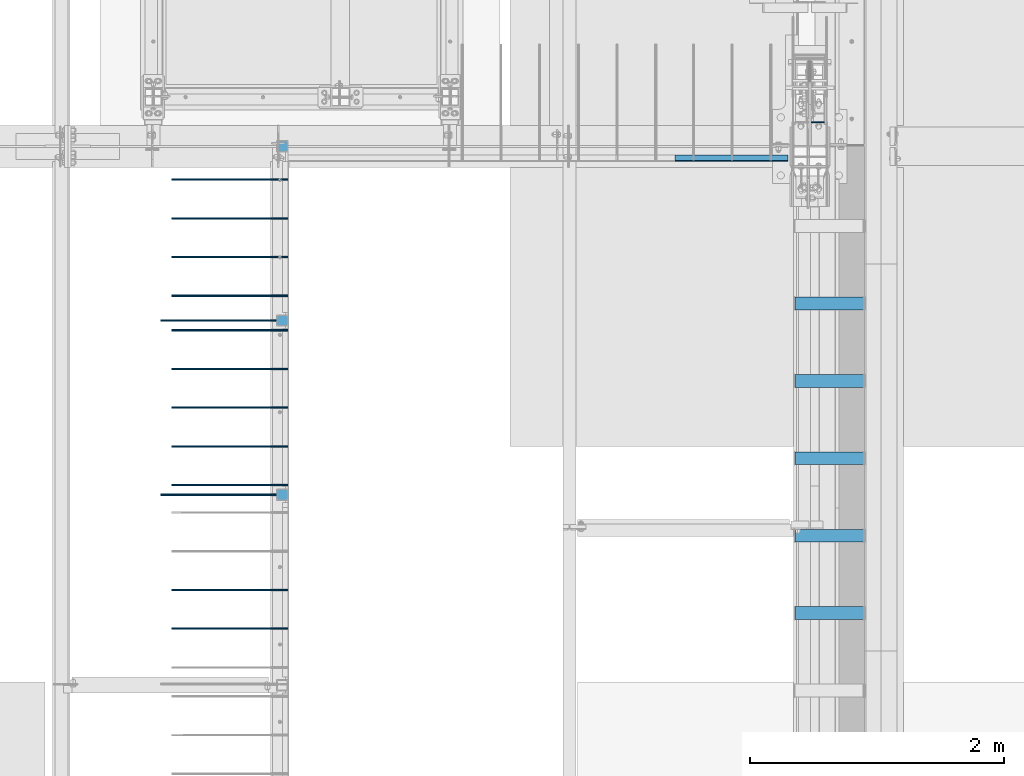
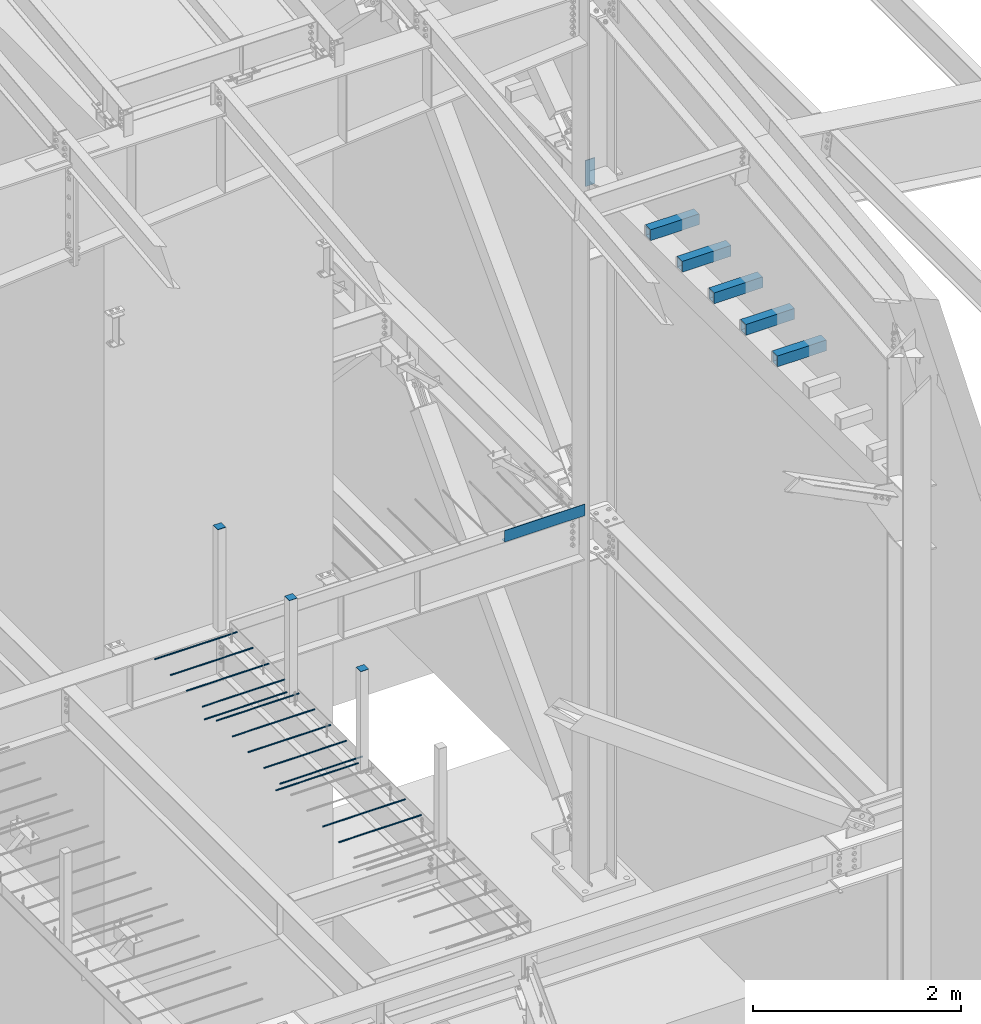
# One storey, part 822 of 1179: 23 beams, 23 elements without a shape of their own.
"""IFC2X3 building model written with IfcOpenShell, lengths in millimetres."""

from ifc_helpers import new_model, si_unit, frame, origin_with_axes, place, context, subcontext, project, spatial, faceted_brep, material, type_object, element, aggregate, save


model = new_model("IFC2X3")

# Units and contexts
model_context = context("Model", 3, precision=1e-05, world=origin_with_axes())
body_context = subcontext(model_context, "Body", "Model", "MODEL_VIEW")
ifc_project = project(units=[si_unit("LENGTHUNIT", "METRE", prefix="MILLI"), si_unit("AREAUNIT", "SQUARE_METRE"), si_unit("VOLUMEUNIT", "CUBIC_METRE"), si_unit("MASSUNIT", "GRAM", prefix="KILO"), si_unit("TIMEUNIT", "SECOND"), si_unit("PLANEANGLEUNIT", "RADIAN"), si_unit("SOLIDANGLEUNIT", "STERADIAN"), si_unit("THERMODYNAMICTEMPERATUREUNIT", "DEGREE_CELSIUS"), si_unit("LUMINOUSINTENSITYUNIT", "LUMEN")], contexts=[model_context])

# Site, building, storey
site_placement = place(None, origin_with_axes())
site = spatial("IfcSite", under=ifc_project, at=site_placement, CompositionType="ELEMENT")
building_placement = place(site_placement, origin_with_axes())
building = spatial("IfcBuilding", under=site, at=building_placement, Name="Undefined", CompositionType="ELEMENT")
storey_placement = place(building_placement, origin_with_axes())
storey = spatial("IfcBuildingStorey", under=building, at=storey_placement, Name="Undefined", CompositionType="ELEMENT", Elevation=0.0)

# Assembly, beam
assembly_1_placement = place(storey_placement, origin_with_axes())
assembly_1 = element("IfcElementAssembly", 1, at=assembly_1_placement, inside=storey, Name="BEAM", AssemblyPlace="NOTDEFINED", PredefinedType="RIGID_FRAME")
ifc_material_1 = material(Name="STEEL/A36")
beam_type_1 = type_object("IfcBeamType", PredefinedType="NOTDEFINED")
beam_1_placement = place(assembly_1_placement, frame((23692.6435, 11366.5, 4235.45000610352), z_axis=(1.0, 0.0, 0.0), x_axis=(0.0, 0.0, -1.0)))
beam_1 = element("IfcBeam", 2, at=beam_1_placement, type_object=beam_type_1, material=ifc_material_1, Name="BENT_PLATE", context=body_context, shape_type="Brep", body=[
    faceted_brep([(0.0, -3.17499999999927, -445.2935), (0.0, -3.17499999999927, 445.2935), (0.0, 3.17499999999927, 445.2935), (0.0, 3.17499999999927, -445.2935), (127.000006103516, 3.17499999999927, 445.2935), (127.000006103516, 3.17499999999927, -445.2935), (133.350006103517, -3.17499999999927, -445.2935), (133.350006103517, -3.17499999999927, 445.2935), (127.000006103516, 47.6249992370613, 445.2935), (127.000006103516, 47.6249992370613, -445.2935), (133.350006103517, 47.6249992370613, 445.2935), (133.350006103517, 47.6249992370613, -445.2935)], [[[0, 1, 2, 3]], [[3, 2, 4, 5]], [[1, 0, 6, 7]], [[5, 4, 8, 9]], [[4, 2, 1, 7, 10, 8]], [[7, 6, 11, 10]], [[6, 0, 3, 5, 9, 11]], [[10, 11, 9, 8]]]),
])
aggregate(assembly_1, [beam_1])

assembly_2_placement = place(storey_placement, origin_with_axes())
assembly_2 = element("IfcElementAssembly", 3, at=assembly_2_placement, inside=storey, Name="COLUMN", AssemblyPlace="NOTDEFINED", PredefinedType="RIGID_FRAME")
beam_type_2 = type_object("IfcBeamType", PredefinedType="NOTDEFINED")
beam_2_placement = place(assembly_2_placement, frame((20154.9, 8693.15, 5299.8685), z_axis=(1.0, 0.0, 0.0), x_axis=(0.0, 1.0, 0.0)))
beam_2 = element("IfcBeam", 4, at=beam_2_placement, type_object=beam_type_2, material=ifc_material_1, Name="PLATE", context=body_context, shape_type="Brep", body=[
    faceted_brep([(0.0, 2.38150000000041, -44.4500000000007), (0.0, 2.38150000000041, 44.4500000000007), (88.9000000000015, 2.38150000000041, 44.4500000000007), (88.9000000000015, 2.38150000000041, -44.4500000000007), (0.0, -2.38150000000041, 44.4500000000007), (88.9000000000015, -2.38150000000041, 44.4500000000007), (0.0, -2.38150000000041, -44.4500000000007), (88.9000000000015, -2.38150000000041, -44.4500000000007)], [[[0, 1, 2, 3]], [[1, 4, 5, 2]], [[4, 6, 7, 5]], [[6, 0, 3, 7]], [[5, 7, 3, 2]], [[6, 4, 1, 0]]]),
])
aggregate(assembly_2, [beam_2])

assembly_3_placement = place(storey_placement, origin_with_axes())
assembly_3 = element("IfcElementAssembly", 5, at=assembly_3_placement, inside=storey, Name="COLUMN", AssemblyPlace="NOTDEFINED", PredefinedType="RIGID_FRAME")
beam_3_placement = place(assembly_3_placement, frame((20154.9, 10064.75, 5299.8685), z_axis=(1.0, 0.0, 0.0), x_axis=(0.0, 1.0, 0.0)))
beam_3 = element("IfcBeam", 6, at=beam_3_placement, type_object=beam_type_2, material=ifc_material_1, Name="PLATE", context=body_context, shape_type="Brep", body=[
    faceted_brep([(0.0, 2.38150000000041, -44.4500000000007), (0.0, 2.38150000000041, 44.4500000000007), (88.9000000000015, 2.38150000000041, 44.4500000000007), (88.9000000000015, 2.38150000000041, -44.4500000000007), (0.0, -2.38150000000041, 44.4500000000007), (88.9000000000015, -2.38150000000041, 44.4500000000007), (0.0, -2.38150000000041, -44.4500000000007), (88.9000000000015, -2.38150000000041, -44.4500000000007)], [[[0, 1, 2, 3]], [[1, 4, 5, 2]], [[4, 6, 7, 5]], [[6, 0, 3, 7]], [[5, 7, 3, 2]], [[6, 4, 1, 0]]]),
])
aggregate(assembly_3, [beam_3])

assembly_4_placement = place(storey_placement, origin_with_axes())
assembly_4 = element("IfcElementAssembly", 7, at=assembly_4_placement, inside=storey, Name="COLUMN", AssemblyPlace="NOTDEFINED", PredefinedType="RIGID_FRAME")
beam_4_placement = place(assembly_4_placement, frame((20154.9, 11436.35, 5299.8685), z_axis=(1.0, 0.0, 0.0), x_axis=(0.0, 1.0, 0.0)))
beam_4 = element("IfcBeam", 8, at=beam_4_placement, type_object=beam_type_2, material=ifc_material_1, Name="PLATE", context=body_context, shape_type="Brep", body=[
    faceted_brep([(0.0, 2.38150000000041, -44.4500000000007), (0.0, 2.38150000000041, 44.4500000000007), (88.9000000000015, 2.38150000000041, 44.4500000000007), (88.9000000000015, 2.38150000000041, -44.4500000000007), (0.0, -2.38150000000041, 44.4500000000007), (88.9000000000015, -2.38150000000041, 44.4500000000007), (0.0, -2.38150000000041, -44.4500000000007), (88.9000000000015, -2.38150000000041, -44.4500000000007)], [[[0, 1, 2, 3]], [[1, 4, 5, 2]], [[4, 6, 7, 5]], [[6, 0, 3, 7]], [[5, 7, 3, 2]], [[6, 4, 1, 0]]]),
])
aggregate(assembly_4, [beam_4])

assembly_5_placement = place(storey_placement, origin_with_axes())
assembly_5 = element("IfcElementAssembly", 9, at=assembly_5_placement, inside=storey, Name="COLUMN", AssemblyPlace="NOTDEFINED", PredefinedType="RIGID_FRAME")
ifc_material_2 = material(Name="STEEL/A572-GR.50")
beam_type_3 = type_object("IfcBeamType", PredefinedType="NOTDEFINED")
beam_5_placement = place(assembly_5_placement, frame((24317.325, 11671.3, 7861.3), z_axis=(0.0, 0.0, 1.0), x_axis=(1.0, 0.0, 0.0)))
beam_5 = element("IfcBeam", 10, at=beam_5_placement, type_object=beam_type_3, material=ifc_material_2, Name="PLATE", context=body_context, shape_type="Brep", body=[
    faceted_brep([(0.0, 4.76250000000073, -152.4), (0.0, 4.76250000000073, 152.4), (104.775000000001, 4.76250000000073, 152.4), (104.775000000001, 4.76250000000073, -152.4), (0.0, -4.76250000000073, 152.4), (104.775000000001, -4.76250000000073, 152.4), (0.0, -4.76250000000073, -152.4), (104.775000000001, -4.76250000000073, -152.4)], [[[0, 1, 2, 3]], [[1, 4, 5, 2]], [[4, 6, 7, 5]], [[6, 0, 3, 7]], [[5, 7, 3, 2]], [[6, 4, 1, 0]]]),
])
aggregate(assembly_5, [beam_5])

assembly_6_placement = place(storey_placement, origin_with_axes())
assembly_6 = element("IfcElementAssembly", 11, at=assembly_6_placement, inside=storey, Name="BEAM", AssemblyPlace="NOTDEFINED", PredefinedType="RIGID_FRAME")
ifc_material_3 = material()
beam_type_4 = type_object("IfcBeamType", Name="HSS5X4X3/8", PredefinedType="NOTDEFINED")
beam_6_placement = place(assembly_6_placement, frame((24180.8, 7805.75703850264, 8077.19999998781), z_axis=(0.0, 0.0, 1.0), x_axis=(1.0, 0.0, 0.0)))
beam_6 = element("IfcBeam", 12, at=beam_6_placement, type_object=beam_type_4, material=ifc_material_3, Name="BEAM", ObjectType="HSS5X4X3/8", context=body_context, shape_type="Brep", body=[
    faceted_brep([(9.52500000000146, 41.2750000000015, -53.9750000000004), (9.52500000000146, -41.2750000000015, -53.9750000000004), (549.274999999994, -41.2750000000015, -53.9750000000004), (549.274999999994, 41.2750000000015, -53.9750000000004), (9.52500000000146, -41.2750000000015, 53.9750000000004), (549.274999999994, -41.2750000000015, 53.9750000000004), (9.52500000000146, 41.2750000000015, 53.9750000000004), (549.274999999994, 41.2750000000015, 53.9750000000004), (9.52500000000146, 50.7999999999993, -63.5), (9.52500000000146, 50.7999999999993, 63.5), (549.274999999994, 50.7999999999993, 63.5), (549.274999999994, 50.7999999999993, -63.5), (9.52500000000146, -50.7999999999993, 63.5), (549.274999999994, -50.7999999999993, 63.5), (9.52500000000146, -50.7999999999993, -63.5), (549.274999999994, -50.7999999999993, -63.5)], [[[0, 1, 2, 3]], [[1, 4, 5, 2]], [[4, 6, 7, 5]], [[6, 0, 3, 7]], [[8, 9, 10, 11]], [[9, 12, 13, 10]], [[12, 14, 15, 13]], [[14, 8, 11, 15]], [[13, 15, 11, 10], [5, 7, 3, 2]], [[14, 12, 9, 8], [6, 4, 1, 0]]]),
])
aggregate(assembly_6, [beam_6])

assembly_7_placement = place(storey_placement, origin_with_axes())
assembly_7 = element("IfcElementAssembly", 13, at=assembly_7_placement, inside=storey, Name="BEAM", AssemblyPlace="NOTDEFINED", PredefinedType="RIGID_FRAME")
beam_7_placement = place(assembly_7_placement, frame((24180.8, 8415.35703850264, 8077.19999998781), z_axis=(0.0, 0.0, 1.0), x_axis=(1.0, 0.0, 0.0)))
beam_7 = element("IfcBeam", 14, at=beam_7_placement, type_object=beam_type_4, material=ifc_material_3, Name="BEAM", ObjectType="HSS5X4X3/8", context=body_context, shape_type="Brep", body=[
    faceted_brep([(9.52500000000146, 41.2750000000015, -53.9750000000004), (9.52500000000146, -41.2750000000015, -53.9750000000004), (549.274999999994, -41.2750000000015, -53.9750000000004), (549.274999999994, 41.2750000000015, -53.9750000000004), (9.52500000000146, -41.2750000000015, 53.9750000000004), (549.274999999994, -41.2750000000015, 53.9750000000004), (9.52500000000146, 41.2750000000015, 53.9750000000004), (549.274999999994, 41.2750000000015, 53.9750000000004), (9.52500000000146, 50.7999999999993, -63.5), (9.52500000000146, 50.7999999999993, 63.5), (549.274999999994, 50.7999999999993, 63.5), (549.274999999994, 50.7999999999993, -63.5), (9.52500000000146, -50.7999999999993, 63.5), (549.274999999994, -50.7999999999993, 63.5), (9.52500000000146, -50.7999999999993, -63.5), (549.274999999994, -50.7999999999993, -63.5)], [[[0, 1, 2, 3]], [[1, 4, 5, 2]], [[4, 6, 7, 5]], [[6, 0, 3, 7]], [[8, 9, 10, 11]], [[9, 12, 13, 10]], [[12, 14, 15, 13]], [[14, 8, 11, 15]], [[13, 15, 11, 10], [5, 7, 3, 2]], [[14, 12, 9, 8], [6, 4, 1, 0]]]),
])
aggregate(assembly_7, [beam_7])

assembly_8_placement = place(storey_placement, origin_with_axes())
assembly_8 = element("IfcElementAssembly", 15, at=assembly_8_placement, inside=storey, Name="BEAM", AssemblyPlace="NOTDEFINED", PredefinedType="RIGID_FRAME")
beam_8_placement = place(assembly_8_placement, frame((24180.8, 9024.95703850264, 8077.19999998781), z_axis=(0.0, 0.0, 1.0), x_axis=(1.0, 0.0, 0.0)))
beam_8 = element("IfcBeam", 16, at=beam_8_placement, type_object=beam_type_4, material=ifc_material_3, Name="BEAM", ObjectType="HSS5X4X3/8", context=body_context, shape_type="Brep", body=[
    faceted_brep([(9.52500000000146, 41.2750000000015, -53.9750000000004), (9.52500000000146, -41.2750000000015, -53.9750000000004), (549.274999999994, -41.2750000000015, -53.9750000000004), (549.274999999994, 41.2750000000015, -53.9750000000004), (9.52500000000146, -41.2750000000015, 53.9750000000004), (549.274999999994, -41.2750000000015, 53.9750000000004), (9.52500000000146, 41.2750000000015, 53.9750000000004), (549.274999999994, 41.2750000000015, 53.9750000000004), (9.52500000000146, 50.7999999999993, -63.5), (9.52500000000146, 50.7999999999993, 63.5), (549.274999999994, 50.7999999999993, 63.5), (549.274999999994, 50.7999999999993, -63.5), (9.52500000000146, -50.7999999999993, 63.5), (549.274999999994, -50.7999999999993, 63.5), (9.52500000000146, -50.7999999999993, -63.5), (549.274999999994, -50.7999999999993, -63.5)], [[[0, 1, 2, 3]], [[1, 4, 5, 2]], [[4, 6, 7, 5]], [[6, 0, 3, 7]], [[8, 9, 10, 11]], [[9, 12, 13, 10]], [[12, 14, 15, 13]], [[14, 8, 11, 15]], [[13, 15, 11, 10], [5, 7, 3, 2]], [[14, 12, 9, 8], [6, 4, 1, 0]]]),
])
aggregate(assembly_8, [beam_8])

assembly_9_placement = place(storey_placement, origin_with_axes())
assembly_9 = element("IfcElementAssembly", 17, at=assembly_9_placement, inside=storey, Name="BEAM", AssemblyPlace="NOTDEFINED", PredefinedType="RIGID_FRAME")
beam_9_placement = place(assembly_9_placement, frame((24180.8, 9634.55703850264, 8077.19999998781), z_axis=(0.0, 0.0, 1.0), x_axis=(1.0, 0.0, 0.0)))
beam_9 = element("IfcBeam", 18, at=beam_9_placement, type_object=beam_type_4, material=ifc_material_3, Name="BEAM", ObjectType="HSS5X4X3/8", context=body_context, shape_type="Brep", body=[
    faceted_brep([(9.52500000000146, 41.2750000000015, -53.9750000000004), (9.52500000000146, -41.2750000000015, -53.9750000000004), (549.274999999994, -41.2750000000015, -53.9750000000004), (549.274999999994, 41.2750000000015, -53.9750000000004), (9.52500000000146, -41.2750000000015, 53.9750000000004), (549.274999999994, -41.2750000000015, 53.9750000000004), (9.52500000000146, 41.2750000000015, 53.9750000000004), (549.274999999994, 41.2750000000015, 53.9750000000004), (9.52500000000146, 50.7999999999993, -63.5), (9.52500000000146, 50.7999999999993, 63.5), (549.274999999994, 50.7999999999993, 63.5), (549.274999999994, 50.7999999999993, -63.5), (9.52500000000146, -50.7999999999993, 63.5), (549.274999999994, -50.7999999999993, 63.5), (9.52500000000146, -50.7999999999993, -63.5), (549.274999999994, -50.7999999999993, -63.5)], [[[0, 1, 2, 3]], [[1, 4, 5, 2]], [[4, 6, 7, 5]], [[6, 0, 3, 7]], [[8, 9, 10, 11]], [[9, 12, 13, 10]], [[12, 14, 15, 13]], [[14, 8, 11, 15]], [[13, 15, 11, 10], [5, 7, 3, 2]], [[14, 12, 9, 8], [6, 4, 1, 0]]]),
])
aggregate(assembly_9, [beam_9])

assembly_10_placement = place(storey_placement, origin_with_axes())
assembly_10 = element("IfcElementAssembly", 19, at=assembly_10_placement, inside=storey, Name="BEAM", AssemblyPlace="NOTDEFINED", PredefinedType="RIGID_FRAME")
beam_10_placement = place(assembly_10_placement, frame((24180.8, 10244.1570385026, 8077.19999998781), z_axis=(0.0, 0.0, 1.0), x_axis=(1.0, 0.0, 0.0)))
beam_10 = element("IfcBeam", 20, at=beam_10_placement, type_object=beam_type_4, material=ifc_material_3, Name="BEAM", ObjectType="HSS5X4X3/8", context=body_context, shape_type="Brep", body=[
    faceted_brep([(9.52500000000146, 41.2750000000015, -53.9750000000004), (9.52500000000146, -41.2750000000015, -53.9750000000004), (549.274999999994, -41.2750000000015, -53.9750000000004), (549.274999999994, 41.2750000000015, -53.9750000000004), (9.52500000000146, -41.2750000000015, 53.9750000000004), (549.274999999994, -41.2750000000015, 53.9750000000004), (9.52500000000146, 41.2750000000015, 53.9750000000004), (549.274999999994, 41.2750000000015, 53.9750000000004), (9.52500000000146, 50.7999999999993, -63.5), (9.52500000000146, 50.7999999999993, 63.5), (549.274999999994, 50.7999999999993, 63.5), (549.274999999994, 50.7999999999993, -63.5), (9.52500000000146, -50.7999999999993, 63.5), (549.274999999994, -50.7999999999993, 63.5), (9.52500000000146, -50.7999999999993, -63.5), (549.274999999994, -50.7999999999993, -63.5)], [[[0, 1, 2, 3]], [[1, 4, 5, 2]], [[4, 6, 7, 5]], [[6, 0, 3, 7]], [[8, 9, 10, 11]], [[9, 12, 13, 10]], [[12, 14, 15, 13]], [[14, 8, 11, 15]], [[13, 15, 11, 10], [5, 7, 3, 2]], [[14, 12, 9, 8], [6, 4, 1, 0]]]),
])
aggregate(assembly_10, [beam_10])

assembly_11_placement = place(storey_placement, origin_with_axes())
assembly_11 = element("IfcElementAssembly", 21, at=assembly_11_placement, inside=storey, Name="#4 DOWEL", AssemblyPlace="NOTDEFINED", PredefinedType="NOTDEFINED")
ifc_material_4 = material(Name="REBAR/A615-40")
beam_type_5 = type_object("IfcBeamType", Name="#4 DOWEL", PredefinedType="NOTDEFINED")
beam_11_placement = place(assembly_11_placement, frame((19284.95, 10033.0, 4203.70000610352), z_axis=(0.0, 0.0, 1.0), x_axis=(1.0, 0.0, 0.0)))
beam_11 = element("IfcBeam", 22, at=beam_11_placement, type_object=beam_type_5, material=ifc_material_4, Name="#4 DOWEL", ObjectType="#4 DOWEL", context=body_context, shape_type="Brep", body=[
    faceted_brep([(0.0, -6.34999999999854, 0.0), (0.0, -4.49012806053361, -4.49012806053452), (914.399999999994, -4.49012806053452, -4.49012806042992), (914.399999999994, -6.34999999999991, 1.0550138540566e-10), (0.0, 0.0, -6.34999999999991), (914.399999999994, 0.0, -6.34999999989668), (0.0, 4.49012806053361, -4.49012806053452), (914.399999999994, 4.49012806053452, -4.49012806042992), (0.0, 6.34999999999854, 0.0), (914.399999999994, 6.34999999999991, 1.0550138540566e-10), (0.0, 4.49012806053361, 4.49012806053452), (914.399999999995, 4.49012806053452, 4.49012806064184), (0.0, 0.0, 6.34999999999991), (914.399999999995, 0.0, 6.35000000010768), (0.0, -4.49012806053361, 4.49012806053452), (914.399999999995, -4.49012806053452, 4.49012806064184)], [[[0, 1, 2, 3]], [[1, 4, 5, 2]], [[4, 6, 7, 5]], [[6, 8, 9, 7]], [[8, 10, 11, 9]], [[10, 12, 13, 11]], [[12, 14, 15, 13]], [[14, 0, 3, 15]], [[5, 7, 9, 11, 13, 15, 3, 2]], [[14, 12, 10, 8, 6, 4, 1, 0]]]),
])
aggregate(assembly_11, [beam_11])

assembly_12_placement = place(storey_placement, origin_with_axes())
assembly_12 = element("IfcElementAssembly", 23, at=assembly_12_placement, inside=storey, Name="#4 DOWEL", AssemblyPlace="NOTDEFINED", PredefinedType="NOTDEFINED")
beam_12_placement = place(assembly_12_placement, frame((19196.05, 8737.6, 4203.70000610352), z_axis=(0.0, 0.0, 1.0), x_axis=(1.0, 0.0, 0.0)))
beam_12 = element("IfcBeam", 24, at=beam_12_placement, type_object=beam_type_5, material=ifc_material_4, Name="#4 DOWEL", ObjectType="#4 DOWEL", context=body_context, shape_type="Brep", body=[
    faceted_brep([(0.0, -6.34999999999854, 0.0), (0.0, -4.49012806053361, -4.49012806053452), (914.399999999994, -4.49012806053452, -4.49012806042992), (914.399999999994, -6.34999999999991, 1.0550138540566e-10), (0.0, 0.0, -6.34999999999991), (914.399999999994, 0.0, -6.34999999989668), (0.0, 4.49012806053361, -4.49012806053452), (914.399999999994, 4.49012806053452, -4.49012806042992), (0.0, 6.34999999999854, 0.0), (914.399999999994, 6.34999999999991, 1.0550138540566e-10), (0.0, 4.49012806053361, 4.49012806053452), (914.399999999995, 4.49012806053452, 4.49012806064184), (0.0, 0.0, 6.34999999999991), (914.399999999995, 0.0, 6.35000000010768), (0.0, -4.49012806053361, 4.49012806053452), (914.399999999995, -4.49012806053452, 4.49012806064184)], [[[0, 1, 2, 3]], [[1, 4, 5, 2]], [[4, 6, 7, 5]], [[6, 8, 9, 7]], [[8, 10, 11, 9]], [[10, 12, 13, 11]], [[12, 14, 15, 13]], [[14, 0, 3, 15]], [[5, 7, 9, 11, 13, 15, 3, 2]], [[14, 12, 10, 8, 6, 4, 1, 0]]]),
])
aggregate(assembly_12, [beam_12])

assembly_13_placement = place(storey_placement, origin_with_axes())
assembly_13 = element("IfcElementAssembly", 25, at=assembly_13_placement, inside=storey, Name="#4 DOWEL", AssemblyPlace="NOTDEFINED", PredefinedType="NOTDEFINED")
beam_13_placement = place(assembly_13_placement, frame((19196.05, 10109.2, 4203.70000610352), z_axis=(0.0, 0.0, 1.0), x_axis=(1.0, 0.0, 0.0)))
beam_13 = element("IfcBeam", 26, at=beam_13_placement, type_object=beam_type_5, material=ifc_material_4, Name="#4 DOWEL", ObjectType="#4 DOWEL", context=body_context, shape_type="Brep", body=[
    faceted_brep([(0.0, -6.34999999999854, 0.0), (0.0, -4.49012806053361, -4.49012806053452), (914.399999999994, -4.49012806053452, -4.49012806042992), (914.399999999994, -6.34999999999991, 1.0550138540566e-10), (0.0, 0.0, -6.34999999999991), (914.399999999994, 0.0, -6.34999999989668), (0.0, 4.49012806053361, -4.49012806053452), (914.399999999994, 4.49012806053452, -4.49012806042992), (0.0, 6.34999999999854, 0.0), (914.399999999994, 6.34999999999991, 1.0550138540566e-10), (0.0, 4.49012806053361, 4.49012806053452), (914.399999999995, 4.49012806053452, 4.49012806064184), (0.0, 0.0, 6.34999999999991), (914.399999999995, 0.0, 6.35000000010768), (0.0, -4.49012806053361, 4.49012806053452), (914.399999999995, -4.49012806053452, 4.49012806064184)], [[[0, 1, 2, 3]], [[1, 4, 5, 2]], [[4, 6, 7, 5]], [[6, 8, 9, 7]], [[8, 10, 11, 9]], [[10, 12, 13, 11]], [[12, 14, 15, 13]], [[14, 0, 3, 15]], [[5, 7, 9, 11, 13, 15, 3, 2]], [[14, 12, 10, 8, 6, 4, 1, 0]]]),
])
aggregate(assembly_13, [beam_13])

assembly_14_placement = place(storey_placement, origin_with_axes())
assembly_14 = element("IfcElementAssembly", 27, at=assembly_14_placement, inside=storey, Name="#4 DOWEL", AssemblyPlace="NOTDEFINED", PredefinedType="NOTDEFINED")
beam_14_placement = place(assembly_14_placement, frame((19284.95, 11218.8625, 4203.70000610352), z_axis=(0.0, 0.0, 1.0), x_axis=(1.0, 0.0, 0.0)))
beam_14 = element("IfcBeam", 28, at=beam_14_placement, type_object=beam_type_5, material=ifc_material_4, Name="#4 DOWEL", ObjectType="#4 DOWEL", context=body_context, shape_type="Brep", body=[
    faceted_brep([(0.0, -6.34999999999854, 0.0), (0.0, -4.49012806053361, -4.49012806053452), (914.399999999994, -4.49012806053452, -4.49012806042992), (914.399999999994, -6.34999999999991, 1.0550138540566e-10), (0.0, 0.0, -6.34999999999991), (914.399999999994, 0.0, -6.34999999989668), (0.0, 4.49012806053361, -4.49012806053452), (914.399999999994, 4.49012806053452, -4.49012806042992), (0.0, 6.34999999999854, 0.0), (914.399999999994, 6.34999999999991, 1.0550138540566e-10), (0.0, 4.49012806053361, 4.49012806053452), (914.399999999995, 4.49012806053452, 4.49012806064184), (0.0, 0.0, 6.34999999999991), (914.399999999995, 0.0, 6.35000000010768), (0.0, -4.49012806053361, 4.49012806053452), (914.399999999995, -4.49012806053452, 4.49012806064184)], [[[0, 1, 2, 3]], [[1, 4, 5, 2]], [[4, 6, 7, 5]], [[6, 8, 9, 7]], [[8, 10, 11, 9]], [[10, 12, 13, 11]], [[12, 14, 15, 13]], [[14, 0, 3, 15]], [[5, 7, 9, 11, 13, 15, 3, 2]], [[14, 12, 10, 8, 6, 4, 1, 0]]]),
])
aggregate(assembly_14, [beam_14])

assembly_15_placement = place(storey_placement, origin_with_axes())
assembly_15 = element("IfcElementAssembly", 29, at=assembly_15_placement, inside=storey, Name="#4 DOWEL", AssemblyPlace="NOTDEFINED", PredefinedType="NOTDEFINED")
beam_15_placement = place(assembly_15_placement, frame((19284.95, 10914.0625, 4203.70000610352), z_axis=(0.0, 0.0, 1.0), x_axis=(1.0, 0.0, 0.0)))
beam_15 = element("IfcBeam", 30, at=beam_15_placement, type_object=beam_type_5, material=ifc_material_4, Name="#4 DOWEL", ObjectType="#4 DOWEL", context=body_context, shape_type="Brep", body=[
    faceted_brep([(0.0, -6.34999999999854, 0.0), (0.0, -4.49012806053361, -4.49012806053452), (914.399999999994, -4.49012806053452, -4.49012806042992), (914.399999999994, -6.34999999999991, 1.0550138540566e-10), (0.0, 0.0, -6.34999999999991), (914.399999999994, 0.0, -6.34999999989668), (0.0, 4.49012806053361, -4.49012806053452), (914.399999999994, 4.49012806053452, -4.49012806042992), (0.0, 6.34999999999854, 0.0), (914.399999999994, 6.34999999999991, 1.0550138540566e-10), (0.0, 4.49012806053361, 4.49012806053452), (914.399999999995, 4.49012806053452, 4.49012806064184), (0.0, 0.0, 6.34999999999991), (914.399999999995, 0.0, 6.35000000010768), (0.0, -4.49012806053361, 4.49012806053452), (914.399999999995, -4.49012806053452, 4.49012806064184)], [[[0, 1, 2, 3]], [[1, 4, 5, 2]], [[4, 6, 7, 5]], [[6, 8, 9, 7]], [[8, 10, 11, 9]], [[10, 12, 13, 11]], [[12, 14, 15, 13]], [[14, 0, 3, 15]], [[5, 7, 9, 11, 13, 15, 3, 2]], [[14, 12, 10, 8, 6, 4, 1, 0]]]),
])
aggregate(assembly_15, [beam_15])

assembly_16_placement = place(storey_placement, origin_with_axes())
assembly_16 = element("IfcElementAssembly", 31, at=assembly_16_placement, inside=storey, Name="#4 DOWEL", AssemblyPlace="NOTDEFINED", PredefinedType="NOTDEFINED")
beam_16_placement = place(assembly_16_placement, frame((19284.95, 10609.2625, 4203.70000610352), z_axis=(0.0, 0.0, 1.0), x_axis=(1.0, 0.0, 0.0)))
beam_16 = element("IfcBeam", 32, at=beam_16_placement, type_object=beam_type_5, material=ifc_material_4, Name="#4 DOWEL", ObjectType="#4 DOWEL", context=body_context, shape_type="Brep", body=[
    faceted_brep([(0.0, -6.34999999999854, 0.0), (0.0, -4.49012806053361, -4.49012806053452), (914.399999999994, -4.49012806053452, -4.49012806042992), (914.399999999994, -6.34999999999991, 1.0550138540566e-10), (0.0, 0.0, -6.34999999999991), (914.399999999994, 0.0, -6.34999999989668), (0.0, 4.49012806053361, -4.49012806053452), (914.399999999994, 4.49012806053452, -4.49012806042992), (0.0, 6.34999999999854, 0.0), (914.399999999994, 6.34999999999991, 1.0550138540566e-10), (0.0, 4.49012806053361, 4.49012806053452), (914.399999999995, 4.49012806053452, 4.49012806064184), (0.0, 0.0, 6.34999999999991), (914.399999999995, 0.0, 6.35000000010768), (0.0, -4.49012806053361, 4.49012806053452), (914.399999999995, -4.49012806053452, 4.49012806064184)], [[[0, 1, 2, 3]], [[1, 4, 5, 2]], [[4, 6, 7, 5]], [[6, 8, 9, 7]], [[8, 10, 11, 9]], [[10, 12, 13, 11]], [[12, 14, 15, 13]], [[14, 0, 3, 15]], [[5, 7, 9, 11, 13, 15, 3, 2]], [[14, 12, 10, 8, 6, 4, 1, 0]]]),
])
aggregate(assembly_16, [beam_16])

assembly_17_placement = place(storey_placement, origin_with_axes())
assembly_17 = element("IfcElementAssembly", 33, at=assembly_17_placement, inside=storey, Name="#4 DOWEL", AssemblyPlace="NOTDEFINED", PredefinedType="NOTDEFINED")
beam_17_placement = place(assembly_17_placement, frame((19284.95, 10304.4625, 4203.70000610352), z_axis=(0.0, 0.0, 1.0), x_axis=(1.0, 0.0, 0.0)))
beam_17 = element("IfcBeam", 34, at=beam_17_placement, type_object=beam_type_5, material=ifc_material_4, Name="#4 DOWEL", ObjectType="#4 DOWEL", context=body_context, shape_type="Brep", body=[
    faceted_brep([(0.0, -6.34999999999854, 0.0), (0.0, -4.49012806053361, -4.49012806053452), (914.399999999994, -4.49012806053452, -4.49012806042992), (914.399999999994, -6.34999999999991, 1.0550138540566e-10), (0.0, 0.0, -6.34999999999991), (914.399999999994, 0.0, -6.34999999989668), (0.0, 4.49012806053361, -4.49012806053452), (914.399999999994, 4.49012806053452, -4.49012806042992), (0.0, 6.34999999999854, 0.0), (914.399999999994, 6.34999999999991, 1.0550138540566e-10), (0.0, 4.49012806053361, 4.49012806053452), (914.399999999995, 4.49012806053452, 4.49012806064184), (0.0, 0.0, 6.34999999999991), (914.399999999995, 0.0, 6.35000000010768), (0.0, -4.49012806053361, 4.49012806053452), (914.399999999995, -4.49012806053452, 4.49012806064184)], [[[0, 1, 2, 3]], [[1, 4, 5, 2]], [[4, 6, 7, 5]], [[6, 8, 9, 7]], [[8, 10, 11, 9]], [[10, 12, 13, 11]], [[12, 14, 15, 13]], [[14, 0, 3, 15]], [[5, 7, 9, 11, 13, 15, 3, 2]], [[14, 12, 10, 8, 6, 4, 1, 0]]]),
])
aggregate(assembly_17, [beam_17])

assembly_18_placement = place(storey_placement, origin_with_axes())
assembly_18 = element("IfcElementAssembly", 35, at=assembly_18_placement, inside=storey, Name="#4 DOWEL", AssemblyPlace="NOTDEFINED", PredefinedType="NOTDEFINED")
beam_18_placement = place(assembly_18_placement, frame((19284.95, 9728.2, 4203.70000610352), z_axis=(0.0, 0.0, 1.0), x_axis=(1.0, 0.0, 0.0)))
beam_18 = element("IfcBeam", 36, at=beam_18_placement, type_object=beam_type_5, material=ifc_material_4, Name="#4 DOWEL", ObjectType="#4 DOWEL", context=body_context, shape_type="Brep", body=[
    faceted_brep([(0.0, -6.34999999999854, 0.0), (0.0, -4.49012806053361, -4.49012806053452), (914.399999999994, -4.49012806053452, -4.49012806042992), (914.399999999994, -6.34999999999991, 1.0550138540566e-10), (0.0, 0.0, -6.34999999999991), (914.399999999994, 0.0, -6.34999999989668), (0.0, 4.49012806053361, -4.49012806053452), (914.399999999994, 4.49012806053452, -4.49012806042992), (0.0, 6.34999999999854, 0.0), (914.399999999994, 6.34999999999991, 1.0550138540566e-10), (0.0, 4.49012806053361, 4.49012806053452), (914.399999999995, 4.49012806053452, 4.49012806064184), (0.0, 0.0, 6.34999999999991), (914.399999999995, 0.0, 6.35000000010768), (0.0, -4.49012806053361, 4.49012806053452), (914.399999999995, -4.49012806053452, 4.49012806064184)], [[[0, 1, 2, 3]], [[1, 4, 5, 2]], [[4, 6, 7, 5]], [[6, 8, 9, 7]], [[8, 10, 11, 9]], [[10, 12, 13, 11]], [[12, 14, 15, 13]], [[14, 0, 3, 15]], [[5, 7, 9, 11, 13, 15, 3, 2]], [[14, 12, 10, 8, 6, 4, 1, 0]]]),
])
aggregate(assembly_18, [beam_18])

assembly_19_placement = place(storey_placement, origin_with_axes())
assembly_19 = element("IfcElementAssembly", 37, at=assembly_19_placement, inside=storey, Name="#4 DOWEL", AssemblyPlace="NOTDEFINED", PredefinedType="NOTDEFINED")
beam_19_placement = place(assembly_19_placement, frame((19284.95, 9423.4, 4203.70000610352), z_axis=(0.0, 0.0, 1.0), x_axis=(1.0, 0.0, 0.0)))
beam_19 = element("IfcBeam", 38, at=beam_19_placement, type_object=beam_type_5, material=ifc_material_4, Name="#4 DOWEL", ObjectType="#4 DOWEL", context=body_context, shape_type="Brep", body=[
    faceted_brep([(0.0, -6.34999999999854, 0.0), (0.0, -4.49012806053361, -4.49012806053452), (914.399999999994, -4.49012806053452, -4.49012806042992), (914.399999999994, -6.34999999999991, 1.0550138540566e-10), (0.0, 0.0, -6.34999999999991), (914.399999999994, 0.0, -6.34999999989668), (0.0, 4.49012806053361, -4.49012806053452), (914.399999999994, 4.49012806053452, -4.49012806042992), (0.0, 6.34999999999854, 0.0), (914.399999999994, 6.34999999999991, 1.0550138540566e-10), (0.0, 4.49012806053361, 4.49012806053452), (914.399999999995, 4.49012806053452, 4.49012806064184), (0.0, 0.0, 6.34999999999991), (914.399999999995, 0.0, 6.35000000010768), (0.0, -4.49012806053361, 4.49012806053452), (914.399999999995, -4.49012806053452, 4.49012806064184)], [[[0, 1, 2, 3]], [[1, 4, 5, 2]], [[4, 6, 7, 5]], [[6, 8, 9, 7]], [[8, 10, 11, 9]], [[10, 12, 13, 11]], [[12, 14, 15, 13]], [[14, 0, 3, 15]], [[5, 7, 9, 11, 13, 15, 3, 2]], [[14, 12, 10, 8, 6, 4, 1, 0]]]),
])
aggregate(assembly_19, [beam_19])

assembly_20_placement = place(storey_placement, origin_with_axes())
assembly_20 = element("IfcElementAssembly", 39, at=assembly_20_placement, inside=storey, Name="#4 DOWEL", AssemblyPlace="NOTDEFINED", PredefinedType="NOTDEFINED")
beam_20_placement = place(assembly_20_placement, frame((19284.95, 9118.6, 4203.70000610352), z_axis=(0.0, 0.0, 1.0), x_axis=(1.0, 0.0, 0.0)))
beam_20 = element("IfcBeam", 40, at=beam_20_placement, type_object=beam_type_5, material=ifc_material_4, Name="#4 DOWEL", ObjectType="#4 DOWEL", context=body_context, shape_type="Brep", body=[
    faceted_brep([(0.0, -6.34999999999854, 0.0), (0.0, -4.49012806053361, -4.49012806053452), (914.399999999994, -4.49012806053452, -4.49012806042992), (914.399999999994, -6.34999999999991, 1.0550138540566e-10), (0.0, 0.0, -6.34999999999991), (914.399999999994, 0.0, -6.34999999989668), (0.0, 4.49012806053361, -4.49012806053452), (914.399999999994, 4.49012806053452, -4.49012806042992), (0.0, 6.34999999999854, 0.0), (914.399999999994, 6.34999999999991, 1.0550138540566e-10), (0.0, 4.49012806053361, 4.49012806053452), (914.399999999995, 4.49012806053452, 4.49012806064184), (0.0, 0.0, 6.34999999999991), (914.399999999995, 0.0, 6.35000000010768), (0.0, -4.49012806053361, 4.49012806053452), (914.399999999995, -4.49012806053452, 4.49012806064184)], [[[0, 1, 2, 3]], [[1, 4, 5, 2]], [[4, 6, 7, 5]], [[6, 8, 9, 7]], [[8, 10, 11, 9]], [[10, 12, 13, 11]], [[12, 14, 15, 13]], [[14, 0, 3, 15]], [[5, 7, 9, 11, 13, 15, 3, 2]], [[14, 12, 10, 8, 6, 4, 1, 0]]]),
])
aggregate(assembly_20, [beam_20])

assembly_21_placement = place(storey_placement, origin_with_axes())
assembly_21 = element("IfcElementAssembly", 41, at=assembly_21_placement, inside=storey, Name="#4 DOWEL", AssemblyPlace="NOTDEFINED", PredefinedType="NOTDEFINED")
beam_21_placement = place(assembly_21_placement, frame((19284.95, 8813.8, 4203.70000610352), z_axis=(0.0, 0.0, 1.0), x_axis=(1.0, 0.0, 0.0)))
beam_21 = element("IfcBeam", 42, at=beam_21_placement, type_object=beam_type_5, material=ifc_material_4, Name="#4 DOWEL", ObjectType="#4 DOWEL", context=body_context, shape_type="Brep", body=[
    faceted_brep([(0.0, -6.34999999999854, 0.0), (0.0, -4.49012806053361, -4.49012806053452), (914.399999999994, -4.49012806053452, -4.49012806042992), (914.399999999994, -6.34999999999991, 1.0550138540566e-10), (0.0, 0.0, -6.34999999999991), (914.399999999994, 0.0, -6.34999999989668), (0.0, 4.49012806053361, -4.49012806053452), (914.399999999994, 4.49012806053452, -4.49012806042992), (0.0, 6.34999999999854, 0.0), (914.399999999994, 6.34999999999991, 1.0550138540566e-10), (0.0, 4.49012806053361, 4.49012806053452), (914.399999999995, 4.49012806053452, 4.49012806064184), (0.0, 0.0, 6.34999999999991), (914.399999999995, 0.0, 6.35000000010768), (0.0, -4.49012806053361, 4.49012806053452), (914.399999999995, -4.49012806053452, 4.49012806064184)], [[[0, 1, 2, 3]], [[1, 4, 5, 2]], [[4, 6, 7, 5]], [[6, 8, 9, 7]], [[8, 10, 11, 9]], [[10, 12, 13, 11]], [[12, 14, 15, 13]], [[14, 0, 3, 15]], [[5, 7, 9, 11, 13, 15, 3, 2]], [[14, 12, 10, 8, 6, 4, 1, 0]]]),
])
aggregate(assembly_21, [beam_21])

assembly_22_placement = place(storey_placement, origin_with_axes())
assembly_22 = element("IfcElementAssembly", 43, at=assembly_22_placement, inside=storey, Name="#4 DOWEL", AssemblyPlace="NOTDEFINED", PredefinedType="NOTDEFINED")
beam_22_placement = place(assembly_22_placement, frame((19284.95, 7988.3, 4203.70000610352), z_axis=(0.0, 0.0, 1.0), x_axis=(1.0, 0.0, 0.0)))
beam_22 = element("IfcBeam", 44, at=beam_22_placement, type_object=beam_type_5, material=ifc_material_4, Name="#4 DOWEL", ObjectType="#4 DOWEL", context=body_context, shape_type="Brep", body=[
    faceted_brep([(0.0, -6.34999999999854, 0.0), (0.0, -4.49012806053361, -4.49012806053452), (914.399999999994, -4.49012806053452, -4.49012806042992), (914.399999999994, -6.34999999999991, 1.0550138540566e-10), (0.0, 0.0, -6.34999999999991), (914.399999999994, 0.0, -6.34999999989668), (0.0, 4.49012806053361, -4.49012806053452), (914.399999999994, 4.49012806053452, -4.49012806042992), (0.0, 6.34999999999854, 0.0), (914.399999999994, 6.34999999999991, 1.0550138540566e-10), (0.0, 4.49012806053361, 4.49012806053452), (914.399999999995, 4.49012806053452, 4.49012806064184), (0.0, 0.0, 6.34999999999991), (914.399999999995, 0.0, 6.35000000010768), (0.0, -4.49012806053361, 4.49012806053452), (914.399999999995, -4.49012806053452, 4.49012806064184)], [[[0, 1, 2, 3]], [[1, 4, 5, 2]], [[4, 6, 7, 5]], [[6, 8, 9, 7]], [[8, 10, 11, 9]], [[10, 12, 13, 11]], [[12, 14, 15, 13]], [[14, 0, 3, 15]], [[5, 7, 9, 11, 13, 15, 3, 2]], [[14, 12, 10, 8, 6, 4, 1, 0]]]),
])
aggregate(assembly_22, [beam_22])

assembly_23_placement = place(storey_placement, origin_with_axes())
assembly_23 = element("IfcElementAssembly", 45, at=assembly_23_placement, inside=storey, Name="#4 DOWEL", AssemblyPlace="NOTDEFINED", PredefinedType="NOTDEFINED")
beam_23_placement = place(assembly_23_placement, frame((19284.95, 7683.5, 4203.70000610352), z_axis=(0.0, 0.0, 1.0), x_axis=(1.0, 0.0, 0.0)))
beam_23 = element("IfcBeam", 46, at=beam_23_placement, type_object=beam_type_5, material=ifc_material_4, Name="#4 DOWEL", ObjectType="#4 DOWEL", context=body_context, shape_type="Brep", body=[
    faceted_brep([(0.0, -6.34999999999854, 0.0), (0.0, -4.49012806053361, -4.49012806053452), (914.399999999994, -4.49012806053452, -4.49012806042992), (914.399999999994, -6.34999999999991, 1.0550138540566e-10), (0.0, 0.0, -6.34999999999991), (914.399999999994, 0.0, -6.34999999989668), (0.0, 4.49012806053361, -4.49012806053452), (914.399999999994, 4.49012806053452, -4.49012806042992), (0.0, 6.34999999999854, 0.0), (914.399999999994, 6.34999999999991, 1.0550138540566e-10), (0.0, 4.49012806053361, 4.49012806053452), (914.399999999995, 4.49012806053452, 4.49012806064184), (0.0, 0.0, 6.34999999999991), (914.399999999995, 0.0, 6.35000000010768), (0.0, -4.49012806053361, 4.49012806053452), (914.399999999995, -4.49012806053452, 4.49012806064184)], [[[0, 1, 2, 3]], [[1, 4, 5, 2]], [[4, 6, 7, 5]], [[6, 8, 9, 7]], [[8, 10, 11, 9]], [[10, 12, 13, 11]], [[12, 14, 15, 13]], [[14, 0, 3, 15]], [[5, 7, 9, 11, 13, 15, 3, 2]], [[14, 12, 10, 8, 6, 4, 1, 0]]]),
])
aggregate(assembly_23, [beam_23])

save(model, "model.ifc")
